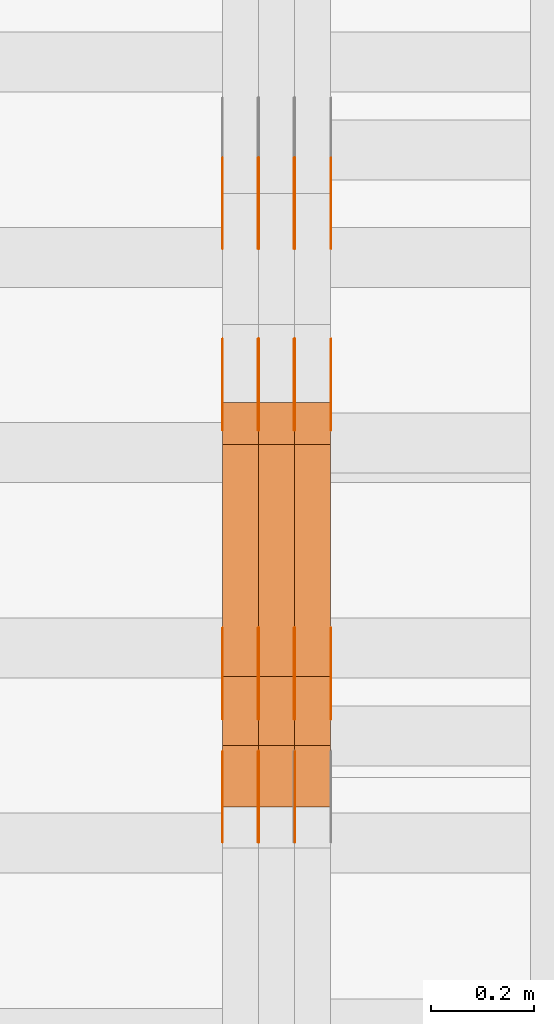
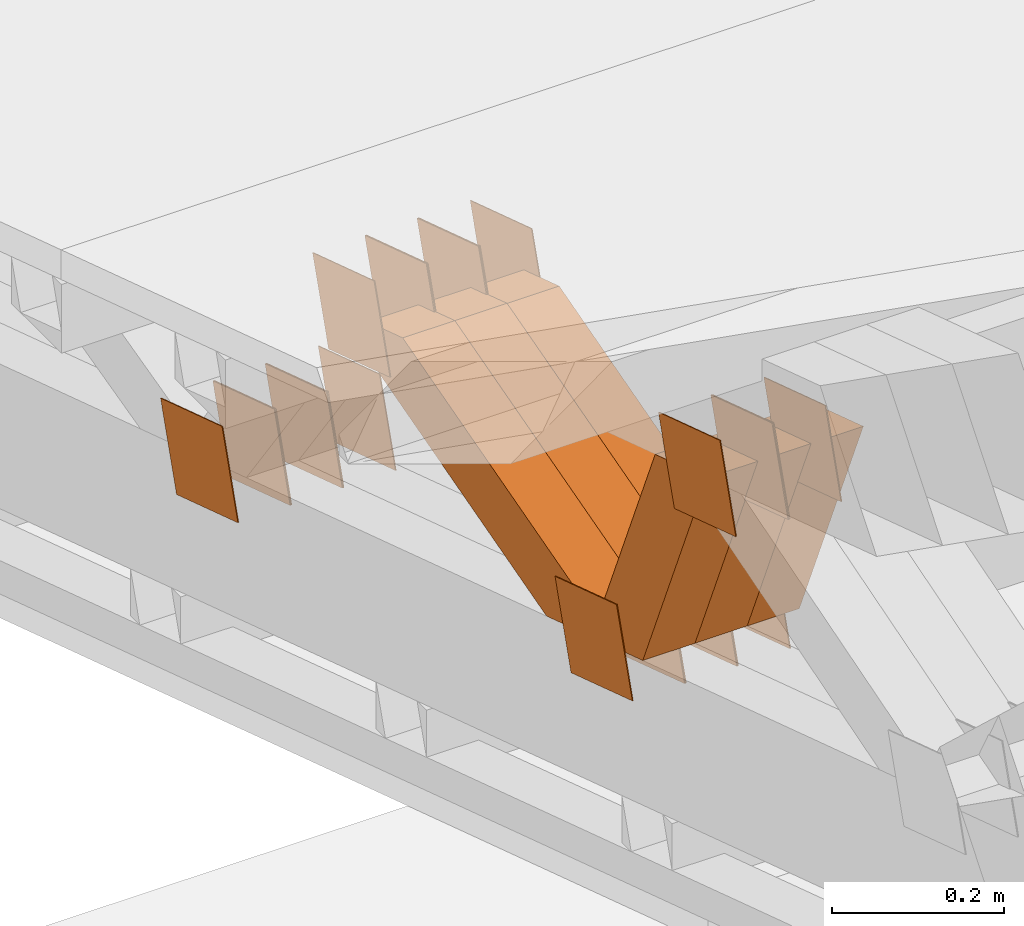
# One storey, part 181 of 385: 28 proxies.
"""IFC2X3 building model written with IfcOpenShell, lengths in millimetres."""

import ifcopenshell
import ifcopenshell.guid

model = None  # the IFC model being written
_history = None  # IfcOwnerHistory: only IFC2X3 demands one
_inside = {}  # id of a spatial element -> (the spatial element, [elements in it])
_under = {}  # id of a project, library or spatial element -> (it, [spatial elements below it])
_declared = {}  # id of a project -> (the project, [libraries it declares])
_typed = {}  # id of a type object -> (the type object, [elements of that type])
_made_of = {}  # id of a material, layer set ... -> (it, [elements and type objects made of it])


def new_model(schema):
    """Start an empty IFC model of exactly this schema.

    Asked for "IFC4X3", IfcOpenShell would pick the latest addendum, in which some entities
    have other attributes; the version numbers below select the first issue.
    IFC2X3 requires an IfcOwnerHistory on every rooted entity: one is made here for all.
    """
    global model, _history
    if schema == "IFC4X3":
        model = ifcopenshell.file(schema_version=(4, 3, 0, 0))
    else:
        model = ifcopenshell.file(schema=schema)
    _inside.clear()
    _under.clear()
    _declared.clear()
    _typed.clear()
    _made_of.clear()
    _history = None
    if model.schema == "IFC2X3":
        org = make("IfcOrganization", Name="unknown")
        user = make(
            "IfcPersonAndOrganization",
            ThePerson=make("IfcPerson", FamilyName="unknown"),
            TheOrganization=org,
        )
        app = make(
            "IfcApplication",
            ApplicationDeveloper=org,
            Version="unknown",
            ApplicationFullName="unknown",
            ApplicationIdentifier="unknown",
        )
        _history = make(
            "IfcOwnerHistory",
            OwningUser=user,
            OwningApplication=app,
            ChangeAction="ADDED",
            CreationDate=0,
        )
    return model


def make(cls, **values):
    """One entity of the class cls with the attributes given. An attribute that is None is left unset."""
    return model.create_entity(
        cls, **{name: value for name, value in values.items() if value is not None}
    )


def entity(cls, *values):
    """Any entity or typed value of the class cls, its attributes in the order of the schema. None: left unset."""
    e = model.create_entity(cls)
    for i, value in enumerate(values):
        if value is not None:
            e[i] = value
    return e


def rooted(cls, **values):
    """An entity with a GlobalId (a new one), such as an element, a storey or a relation."""
    return make(cls, GlobalId=ifcopenshell.guid.new(), OwnerHistory=_history, **values)


def si_unit(unit_type, name, prefix=None):
    """IfcSIUnit, for example si_unit("LENGTHUNIT", "METRE", prefix="MILLI")."""
    return make("IfcSIUnit", UnitType=unit_type, Prefix=prefix, Name=name)


def converted_unit(unit_type, name, factor, base, dimensions=None, offset=None):
    """IfcConversionBasedUnit, such as the inch: factor (a typed value) times the base unit."""
    return make(
        "IfcConversionBasedUnit"
        if offset is None
        else "IfcConversionBasedUnitWithOffset",
        ConversionOffset=offset,
        Dimensions=None
        if dimensions is None
        else entity("IfcDimensionalExponents", *dimensions),
        UnitType=unit_type,
        Name=name,
        ConversionFactor=make(
            "IfcMeasureWithUnit", ValueComponent=factor, UnitComponent=base
        ),
    )


def derived_unit(unit_type, elements):
    """IfcDerivedUnit: a product of units, each with its exponent."""
    return make(
        "IfcDerivedUnit",
        Elements=[
            make("IfcDerivedUnitElement", Unit=unit, Exponent=power)
            for unit, power in elements
        ],
        UnitType=unit_type,
    )


def assignment(units):
    """IfcUnitAssignment: the units of a project."""
    return None if units is None else make("IfcUnitAssignment", Units=units)


def point(xyz):
    """IfcCartesianPoint."""
    return None if xyz is None else make("IfcCartesianPoint", Coordinates=xyz)


def direction(xyz):
    """IfcDirection."""
    return None if xyz is None else make("IfcDirection", DirectionRatios=xyz)


def frame(location, z_axis=None, x_axis=None):
    """IfcAxis2Placement3D, a coordinate frame: its origin and axes. An axis left out is left unset."""
    return make(
        "IfcAxis2Placement3D",
        Location=point(location),
        Axis=direction(z_axis),
        RefDirection=direction(x_axis),
    )


def origin():
    """The frame at (0, 0, 0) with its axes left unset."""
    return frame((0.0, 0.0, 0.0))


def place(relative_to, where):
    """IfcLocalPlacement: puts the frame where relative to a parent placement (None: the world)."""
    return make(
        "IfcLocalPlacement", PlacementRelTo=relative_to, RelativePlacement=where
    )


def context(
    kind, dimensions, precision=None, world=None, true_north=None, identifier=None
):
    """IfcGeometricRepresentationContext, for example the 3D "Model" context."""
    return make(
        "IfcGeometricRepresentationContext",
        ContextIdentifier=identifier,
        ContextType=kind,
        CoordinateSpaceDimension=dimensions,
        Precision=precision,
        WorldCoordinateSystem=world,
        TrueNorth=true_north,
    )


def subcontext(parent, identifier, kind, view, scale=None):
    """IfcGeometricRepresentationSubContext, for example "Body" below "Model"."""
    return make(
        "IfcGeometricRepresentationSubContext",
        ContextIdentifier=identifier,
        ContextType=kind,
        ParentContext=parent,
        TargetScale=scale,
        TargetView=view,
    )


def project(units=None, contexts=None):
    """IfcProject with its units and contexts."""
    return rooted(
        "IfcProject",
        Name="project",
        RepresentationContexts=contexts,
        UnitsInContext=assignment(units),
    )


def spatial(cls, under=None, at=None, **own):
    """A site, building, storey or space (cls), placed at a placement, below another one or the project."""
    s = rooted(cls, ObjectPlacement=at, **own)
    if under is not None:
        _under.setdefault(under.id(), (under, []))[1].append(s)
    return s


def polyline(points):
    """IfcPolyline through the points."""
    return make("IfcPolyline", Points=[point(p) for p in points])


def outline(outer, holes=None, kind="AREA"):
    """IfcArbitraryClosedProfileDef: a profile drawn as a closed curve; with holes, ...WithVoids."""
    if holes is None:
        return make("IfcArbitraryClosedProfileDef", ProfileType=kind, OuterCurve=outer)
    return make(
        "IfcArbitraryProfileDefWithVoids",
        ProfileType=kind,
        OuterCurve=outer,
        InnerCurves=holes,
    )


def extrude(swept, where, along, depth):
    """IfcExtrudedAreaSolid: the profile swept, set in the frame where, extruded along a direction by depth."""
    return make(
        "IfcExtrudedAreaSolid",
        SweptArea=swept,
        Position=where,
        ExtrudedDirection=direction(along),
        Depth=depth,
    )


def shape(context_of_items, identifier, shape_type, items):
    """IfcShapeRepresentation: the items that make up one representation, for example the "Body"."""
    return make(
        "IfcShapeRepresentation",
        ContextOfItems=context_of_items,
        RepresentationIdentifier=identifier,
        RepresentationType=shape_type,
        Items=items,
    )


def source(mapping_origin, context_of_items, identifier, shape_type, items):
    """IfcRepresentationMap: a shape defined once, which mapped items show again and again."""
    return make(
        "IfcRepresentationMap",
        MappingOrigin=mapping_origin,
        MappedRepresentation=shape(context_of_items, identifier, shape_type, items),
    )


def transform(
    local_origin,
    x_axis=None,
    y_axis=None,
    z_axis=None,
    scale=None,
    scale2=None,
    scale3=None,
    uniform=True,
):
    """IfcCartesianTransformationOperator3D, or its non-uniform kind. x_axis, y_axis, z_axis: its Axis1, 2, 3."""
    if uniform:
        return make(
            "IfcCartesianTransformationOperator3D",
            Axis1=direction(x_axis),
            Axis2=direction(y_axis),
            LocalOrigin=point(local_origin),
            Scale=scale,
            Axis3=direction(z_axis),
        )
    return make(
        "IfcCartesianTransformationOperator3DnonUniform",
        Axis1=direction(x_axis),
        Axis2=direction(y_axis),
        LocalOrigin=point(local_origin),
        Scale=scale,
        Axis3=direction(z_axis),
        Scale2=scale2,
        Scale3=scale3,
    )


def mapped(mapping_source, mapping_target):
    """IfcMappedItem: shows the shape of a source again, moved by a transform."""
    return make(
        "IfcMappedItem", MappingSource=mapping_source, MappingTarget=mapping_target
    )


def material(Name=None, Category=None):
    """IfcMaterial."""
    return make("IfcMaterial", Name=Name, Category=Category)


def made_of(thing, what):
    """Note that an element or type object is made of a material, layer set ...; save() writes the relation."""
    if what is not None:
        _made_of.setdefault(what.id(), (what, []))[1].append(thing)
    return thing


def type_object(cls, material=None, **own):
    """A type object (cls), such as IfcWallType, which elements share."""
    return made_of(rooted(cls, **own), material)


def type_shapes(of_type, sources):
    """Give a type object the sources (RepresentationMaps) that its elements show as mapped items."""
    of_type.RepresentationMaps = sources


def element(
    cls,
    number,
    at=None,
    inside=None,
    cuts=None,
    type_object=None,
    material=None,
    context=None,
    identifier="Body",
    shape_type=None,
    held_by="IfcProductDefinitionShape",
    body=None,
    shapes=None,
    **own,
):
    """One element of the class cls, such as IfcWall. Its Tag is "e" and its number.

    at: its placement. inside: the storey or other place that contains it. cuts: it is an
    opening in that element (IfcRelVoidsElement). A single representation is given by context,
    identifier, shape_type and body (its items); several are given by shapes. held_by: the class
    of the entity that holds the representations. save() writes the other relations.
    """
    e = rooted(cls, Tag="e%d" % number, ObjectPlacement=at, **own)
    if body is not None:
        shapes = [shape(context, identifier, shape_type, body)]
    if shapes is not None:
        e.Representation = make(held_by, Representations=shapes)
    if inside is not None:
        _inside.setdefault(inside.id(), (inside, []))[1].append(e)
    if cuts is not None:
        rooted(
            "IfcRelVoidsElement", RelatingBuildingElement=cuts, RelatedOpeningElement=e
        )
    if type_object is not None:
        _typed.setdefault(type_object.id(), (type_object, []))[1].append(e)
    return made_of(e, material)


def aggregate(whole, parts):
    """IfcRelAggregates: a whole, such as a stair, and the parts it consists of."""
    return rooted("IfcRelAggregates", RelatingObject=whole, RelatedObjects=parts)


def save(model, path):
    """Write the relations noted so far, then the file.

    IfcRelAggregates (storeys below a building ...), IfcRelContainedInSpatialStructure (elements
    in a storey), IfcRelDefinesByType, IfcRelAssociatesMaterial and IfcRelDeclares: one each for
    every whole, place, type object, material and project.
    """
    for whole, parts in _under.values():
        aggregate(whole, parts)
    for where, things in _inside.values():
        rooted(
            "IfcRelContainedInSpatialStructure",
            RelatedElements=things,
            RelatingStructure=where,
        )
    for kind, things in _typed.values():
        rooted("IfcRelDefinesByType", RelatedObjects=things, RelatingType=kind)
    for what, things in _made_of.values():
        rooted("IfcRelAssociatesMaterial", RelatedObjects=things, RelatingMaterial=what)
    for by, libraries in _declared.values():
        rooted("IfcRelDeclares", RelatingContext=by, RelatedDefinitions=libraries)
    model.write(path)


model = new_model("IFC2X3")

# Units and contexts
model_context = context("Model", 3, precision=0.01, world=origin(), true_north=direction((6.12303176911189e-17, 1.0)))
body_context = subcontext(model_context, "Body", "Model", "MODEL_VIEW")
ifc_project = project(units=[si_unit("LENGTHUNIT", "METRE", prefix="MILLI"), si_unit("AREAUNIT", "SQUARE_METRE"), si_unit("VOLUMEUNIT", "CUBIC_METRE"), converted_unit("PLANEANGLEUNIT", "DEGREE", entity("IfcRatioMeasure", 0.0174532925199433), si_unit("PLANEANGLEUNIT", "RADIAN"), dimensions=[0, 0, 0, 0, 0, 0, 0]), si_unit("MASSUNIT", "GRAM", prefix="KILO"), derived_unit("MASSDENSITYUNIT", [(si_unit("MASSUNIT", "GRAM", prefix="KILO"), 1), (si_unit("LENGTHUNIT", "METRE"), -3)]), si_unit("TIMEUNIT", "SECOND"), si_unit("FREQUENCYUNIT", "HERTZ"), si_unit("THERMODYNAMICTEMPERATUREUNIT", "DEGREE_CELSIUS"), derived_unit("THERMALTRANSMITTANCEUNIT", [(si_unit("MASSUNIT", "GRAM", prefix="KILO"), 1), (si_unit("THERMODYNAMICTEMPERATUREUNIT", "KELVIN"), -1), (si_unit("TIMEUNIT", "SECOND"), -3)]), derived_unit("VOLUMETRICFLOWRATEUNIT", [(si_unit("LENGTHUNIT", "METRE"), 3), (si_unit("TIMEUNIT", "SECOND"), -1)]), si_unit("ELECTRICCURRENTUNIT", "AMPERE"), si_unit("ELECTRICVOLTAGEUNIT", "VOLT"), si_unit("POWERUNIT", "WATT"), si_unit("FORCEUNIT", "NEWTON", prefix="KILO"), si_unit("ILLUMINANCEUNIT", "LUX"), si_unit("LUMINOUSFLUXUNIT", "LUMEN"), si_unit("LUMINOUSINTENSITYUNIT", "CANDELA"), derived_unit("USERDEFINED", [(si_unit("MASSUNIT", "GRAM", prefix="KILO"), -1), (si_unit("LENGTHUNIT", "METRE"), -2), (si_unit("TIMEUNIT", "SECOND"), 3), (si_unit("LUMINOUSFLUXUNIT", "LUMEN"), 1)]), derived_unit("LINEARVELOCITYUNIT", [(si_unit("LENGTHUNIT", "METRE"), 1), (si_unit("TIMEUNIT", "SECOND"), -1)]), si_unit("PRESSUREUNIT", "PASCAL"), derived_unit("USERDEFINED", [(si_unit("LENGTHUNIT", "METRE"), -2), (si_unit("MASSUNIT", "GRAM", prefix="KILO"), 1), (si_unit("TIMEUNIT", "SECOND"), -2)])], contexts=[model_context])

# Site, building, storey
site_placement = place(None, origin())
site = spatial("IfcSite", under=ifc_project, at=site_placement, CompositionType="ELEMENT")
building_placement = place(site_placement, origin())
building = spatial("IfcBuilding", under=site, at=building_placement, CompositionType="ELEMENT")
storey_placement = place(building_placement, origin())
storey = spatial("IfcBuildingStorey", under=building, at=storey_placement, Name="Default", CompositionType="ELEMENT", Elevation=0.0)

# Proxies
ifc_material_1 = material(Name="IfcSurfaceStyle #24212")
building_element_proxy_type_1 = type_object("IfcBuildingElementProxyType", PredefinedType="NOTDEFINED", material=ifc_material_1)
shared_shape_1 = source(origin(), body_context, "Body", "SweptSolid", [
    extrude(outline(polyline([(-74.9998888504569, -59.9999264677525), (74.999884859074, -59.9999264677525), (74.9998699895559, 59.9999264677525), (-74.999865998173, 59.9999264677525), (-74.9998888504569, -59.9999264677525)])), frame((74.9999170714918, 60.0000016373507, 0.0), z_axis=(0.0, 0.0, 1.0), x_axis=(-1.0, 0.0, 0.0)), (0.0, 0.0, 1.0), 1.3),
])
type_shapes(building_element_proxy_type_1, [shared_shape_1])
proxy_1_placement = place(building_placement, frame((316.299999999986, 23182.5962361838, 1409.76695322432), z_axis=(-1.0, 0.0, 0.0), x_axis=(0.0, -0.951056516295154, 0.309016994374948)))
element("IfcBuildingElementProxy", 1, at=proxy_1_placement, inside=storey, type_object=building_element_proxy_type_1, material=ifc_material_1, context=body_context, shape_type="MappedRepresentation", body=[
    mapped(shared_shape_1, transform((0.0, 0.0, 0.0), scale=1.0)),
])
ifc_material_2 = material(Name="IfcSurfaceStyle #24155")
building_element_proxy_type_2 = type_object("IfcBuildingElementProxyType", PredefinedType="NOTDEFINED", material=ifc_material_2)
shared_shape_2 = source(origin(), body_context, "Body", "SweptSolid", [
    extrude(outline(polyline([(-74.9998888504569, -59.9999264677525), (74.999884859074, -59.9999264677525), (74.9998699895559, 59.9999264677525), (-74.999865998173, 59.9999264677525), (-74.9998888504569, -59.9999264677525)])), frame((74.9999170714918, 60.0000016373507, 0.0), z_axis=(0.0, 0.0, 1.0), x_axis=(-1.0, 0.0, 0.0)), (0.0, 0.0, 1.0), 1.29999999999999),
])
type_shapes(building_element_proxy_type_2, [shared_shape_2])
proxy_2_placement = place(building_placement, frame((245.0, 23182.5962361838, 1409.76695322432), z_axis=(-1.0, 0.0, 0.0), x_axis=(0.0, -0.951056516295154, 0.309016994374948)))
element("IfcBuildingElementProxy", 2, at=proxy_2_placement, inside=storey, type_object=building_element_proxy_type_2, material=ifc_material_2, context=body_context, shape_type="MappedRepresentation", body=[
    mapped(shared_shape_2, transform((0.0, 0.0, 0.0), scale=1.0)),
])
ifc_material_3 = material(Name="IfcSurfaceStyle #24098")
building_element_proxy_type_3 = type_object("IfcBuildingElementProxyType", PredefinedType="NOTDEFINED", material=ifc_material_3)
shared_shape_3 = source(origin(), body_context, "Body", "SweptSolid", [
    extrude(outline(polyline([(-74.9998888504569, -59.9999264677525), (74.999884859074, -59.9999264677525), (74.9998699895559, 59.9999264677525), (-74.999865998173, 59.9999264677525), (-74.9998888504569, -59.9999264677525)])), frame((74.9999170714918, 60.0000016373507, 0.0), z_axis=(0.0, 0.0, 1.0), x_axis=(-1.0, 0.0, 0.0)), (0.0, 0.0, 1.0), 1.29999999999999),
])
type_shapes(building_element_proxy_type_3, [shared_shape_3])
proxy_3_placement = place(building_placement, frame((246.299999999986, 23182.5962361838, 1409.76695322432), z_axis=(-1.0, 0.0, 0.0), x_axis=(0.0, -0.951056516295154, 0.309016994374948)))
element("IfcBuildingElementProxy", 3, at=proxy_3_placement, inside=storey, type_object=building_element_proxy_type_3, material=ifc_material_3, context=body_context, shape_type="MappedRepresentation", body=[
    mapped(shared_shape_3, transform((0.0, 0.0, 0.0), scale=1.0)),
])
ifc_material_4 = material(Name="IfcSurfaceStyle #24041")
building_element_proxy_type_4 = type_object("IfcBuildingElementProxyType", PredefinedType="NOTDEFINED", material=ifc_material_4)
shared_shape_4 = source(origin(), body_context, "Body", "SweptSolid", [
    extrude(outline(polyline([(-74.9998888504569, -59.9999264677525), (74.999884859074, -59.9999264677525), (74.9998699895559, 59.9999264677525), (-74.999865998173, 59.9999264677525), (-74.9998888504569, -59.9999264677525)])), frame((74.9999170714918, 60.0000016373507, 0.0), z_axis=(0.0, 0.0, 1.0), x_axis=(-1.0, 0.0, 0.0)), (0.0, 0.0, 1.0), 1.29999999999999),
])
type_shapes(building_element_proxy_type_4, [shared_shape_4])
proxy_4_placement = place(building_placement, frame((175.0, 23182.5962361838, 1409.76695322432), z_axis=(-1.0, 0.0, 0.0), x_axis=(0.0, -0.951056516295154, 0.309016994374948)))
element("IfcBuildingElementProxy", 4, at=proxy_4_placement, inside=storey, type_object=building_element_proxy_type_4, material=ifc_material_4, context=body_context, shape_type="MappedRepresentation", body=[
    mapped(shared_shape_4, transform((0.0, 0.0, 0.0), scale=1.0)),
])
ifc_material_5 = material(Name="IfcSurfaceStyle #23984")
building_element_proxy_type_5 = type_object("IfcBuildingElementProxyType", PredefinedType="NOTDEFINED", material=ifc_material_5)
shared_shape_5 = source(origin(), body_context, "Body", "SweptSolid", [
    extrude(outline(polyline([(-75.000111611545, -60.0000599592451), (75.0000887592491, -60.0000599592451), (75.000111611545, 60.0000599592451), (-75.0000887592492, 60.0000599592451), (-75.000111611545, -60.0000599592451)])), frame((75.000111611545, 60.0000599592451, 0.0), z_axis=(0.0, 0.0, 1.0), x_axis=(-1.0, 0.0, 0.0)), (0.0, 0.0, 1.0), 1.3),
])
type_shapes(building_element_proxy_type_5, [shared_shape_5])
proxy_5_placement = place(building_placement, frame((386.299999999986, 23422.738257852, 1031.33757447264), z_axis=(-1.0, 0.0, 0.0), x_axis=(0.0, -0.951056516295124, 0.309016994375039)))
element("IfcBuildingElementProxy", 5, at=proxy_5_placement, inside=storey, type_object=building_element_proxy_type_5, material=ifc_material_5, context=body_context, shape_type="MappedRepresentation", body=[
    mapped(shared_shape_5, transform((0.0, 0.0, 0.0), scale=1.0)),
])
ifc_material_6 = material(Name="IfcSurfaceStyle #23927")
building_element_proxy_type_6 = type_object("IfcBuildingElementProxyType", PredefinedType="NOTDEFINED", material=ifc_material_6)
shared_shape_6 = source(origin(), body_context, "Body", "SweptSolid", [
    extrude(outline(polyline([(-75.000111611545, -60.0000599592451), (75.0000887592491, -60.0000599592451), (75.000111611545, 60.0000599592451), (-75.0000887592492, 60.0000599592451), (-75.000111611545, -60.0000599592451)])), frame((75.000111611545, 60.0000599592451, 0.0), z_axis=(0.0, 0.0, 1.0), x_axis=(-1.0, 0.0, 0.0)), (0.0, 0.0, 1.0), 1.3),
])
type_shapes(building_element_proxy_type_6, [shared_shape_6])
proxy_6_placement = place(building_placement, frame((315.0, 23422.738257852, 1031.33757447264), z_axis=(-1.0, 0.0, 0.0), x_axis=(0.0, -0.951056516295124, 0.309016994375039)))
element("IfcBuildingElementProxy", 6, at=proxy_6_placement, inside=storey, type_object=building_element_proxy_type_6, material=ifc_material_6, context=body_context, shape_type="MappedRepresentation", body=[
    mapped(shared_shape_6, transform((0.0, 0.0, 0.0), scale=1.0)),
])
ifc_material_7 = material(Name="IfcSurfaceStyle #23870")
building_element_proxy_type_7 = type_object("IfcBuildingElementProxyType", PredefinedType="NOTDEFINED", material=ifc_material_7)
shared_shape_7 = source(origin(), body_context, "Body", "SweptSolid", [
    extrude(outline(polyline([(-75.000111611545, -60.0000599592451), (75.0000887592491, -60.0000599592451), (75.000111611545, 60.0000599592451), (-75.0000887592492, 60.0000599592451), (-75.000111611545, -60.0000599592451)])), frame((75.000111611545, 60.0000599592451, 0.0), z_axis=(0.0, 0.0, 1.0), x_axis=(-1.0, 0.0, 0.0)), (0.0, 0.0, 1.0), 1.3),
])
type_shapes(building_element_proxy_type_7, [shared_shape_7])
proxy_7_placement = place(building_placement, frame((316.299999999986, 23422.738257852, 1031.33757447264), z_axis=(-1.0, 0.0, 0.0), x_axis=(0.0, -0.951056516295124, 0.309016994375039)))
element("IfcBuildingElementProxy", 7, at=proxy_7_placement, inside=storey, type_object=building_element_proxy_type_7, material=ifc_material_7, context=body_context, shape_type="MappedRepresentation", body=[
    mapped(shared_shape_7, transform((0.0, 0.0, 0.0), scale=1.0)),
])
ifc_material_8 = material(Name="IfcSurfaceStyle #23813")
building_element_proxy_type_8 = type_object("IfcBuildingElementProxyType", PredefinedType="NOTDEFINED", material=ifc_material_8)
shared_shape_8 = source(origin(), body_context, "Body", "SweptSolid", [
    extrude(outline(polyline([(-75.000111611545, -60.0000599592451), (75.0000887592491, -60.0000599592451), (75.000111611545, 60.0000599592451), (-75.0000887592492, 60.0000599592451), (-75.000111611545, -60.0000599592451)])), frame((75.000111611545, 60.0000599592451, 0.0), z_axis=(0.0, 0.0, 1.0), x_axis=(-1.0, 0.0, 0.0)), (0.0, 0.0, 1.0), 1.29999999999999),
])
type_shapes(building_element_proxy_type_8, [shared_shape_8])
proxy_8_placement = place(building_placement, frame((245.0, 23422.738257852, 1031.33757447264), z_axis=(-1.0, 0.0, 0.0), x_axis=(0.0, -0.951056516295124, 0.309016994375039)))
element("IfcBuildingElementProxy", 8, at=proxy_8_placement, inside=storey, type_object=building_element_proxy_type_8, material=ifc_material_8, context=body_context, shape_type="MappedRepresentation", body=[
    mapped(shared_shape_8, transform((0.0, 0.0, 0.0), scale=1.0)),
])
ifc_material_9 = material(Name="IfcSurfaceStyle #23756")
building_element_proxy_type_9 = type_object("IfcBuildingElementProxyType", PredefinedType="NOTDEFINED", material=ifc_material_9)
shared_shape_9 = source(origin(), body_context, "Body", "SweptSolid", [
    extrude(outline(polyline([(-75.000111611545, -60.0000599592451), (75.0000887592491, -60.0000599592451), (75.000111611545, 60.0000599592451), (-75.0000887592492, 60.0000599592451), (-75.000111611545, -60.0000599592451)])), frame((75.000111611545, 60.0000599592451, 0.0), z_axis=(0.0, 0.0, 1.0), x_axis=(-1.0, 0.0, 0.0)), (0.0, 0.0, 1.0), 1.29999999999999),
])
type_shapes(building_element_proxy_type_9, [shared_shape_9])
proxy_9_placement = place(building_placement, frame((246.299999999986, 23422.738257852, 1031.33757447264), z_axis=(-1.0, 0.0, 0.0), x_axis=(0.0, -0.951056516295124, 0.309016994375039)))
element("IfcBuildingElementProxy", 9, at=proxy_9_placement, inside=storey, type_object=building_element_proxy_type_9, material=ifc_material_9, context=body_context, shape_type="MappedRepresentation", body=[
    mapped(shared_shape_9, transform((0.0, 0.0, 0.0), scale=1.0)),
])
ifc_material_10 = material(Name="IfcSurfaceStyle #23699")
building_element_proxy_type_10 = type_object("IfcBuildingElementProxyType", PredefinedType="NOTDEFINED", material=ifc_material_10)
shared_shape_10 = source(origin(), body_context, "Body", "SweptSolid", [
    extrude(outline(polyline([(-75.000111611545, -60.0000599592451), (75.0000887592491, -60.0000599592451), (75.000111611545, 60.0000599592451), (-75.0000887592492, 60.0000599592451), (-75.000111611545, -60.0000599592451)])), frame((75.000111611545, 60.0000599592451, 0.0), z_axis=(0.0, 0.0, 1.0), x_axis=(-1.0, 0.0, 0.0)), (0.0, 0.0, 1.0), 1.29999999999999),
])
type_shapes(building_element_proxy_type_10, [shared_shape_10])
proxy_10_placement = place(building_placement, frame((175.0, 23422.738257852, 1031.33757447264), z_axis=(-1.0, 0.0, 0.0), x_axis=(0.0, -0.951056516295124, 0.309016994375039)))
element("IfcBuildingElementProxy", 10, at=proxy_10_placement, inside=storey, type_object=building_element_proxy_type_10, material=ifc_material_10, context=body_context, shape_type="MappedRepresentation", body=[
    mapped(shared_shape_10, transform((0.0, 0.0, 0.0), scale=1.0)),
])
ifc_material_11 = material(Name="IfcSurfaceStyle #23300")
building_element_proxy_type_11 = type_object("IfcBuildingElementProxyType", PredefinedType="NOTDEFINED", material=ifc_material_11)
shared_shape_11 = source(origin(), body_context, "Body", "SweptSolid", [
    extrude(outline(polyline([(-74.9999766548731, -60.0000019113547), (75.000223715922, -60.0000019113547), (74.9997444633404, 60.0000019113548), (-74.9999915243893, 60.0000019113547), (-74.9999766548731, -60.0000019113547)])), frame((75.0002237159219, 60.0000770809529, 0.0), z_axis=(0.0, 0.0, 1.0), x_axis=(-1.0, 0.0, 0.0)), (0.0, 0.0, 1.0), 1.3),
])
type_shapes(building_element_proxy_type_11, [shared_shape_11])
proxy_11_placement = place(building_placement, frame((386.299999999986, 23985.88473314, 1148.76266928562), z_axis=(-1.0, 0.0, 0.0), x_axis=(0.0, -0.951056516295154, 0.309016994374948)))
element("IfcBuildingElementProxy", 11, at=proxy_11_placement, inside=storey, type_object=building_element_proxy_type_11, material=ifc_material_11, context=body_context, shape_type="MappedRepresentation", body=[
    mapped(shared_shape_11, transform((0.0, 0.0, 0.0), scale=1.0)),
])
ifc_material_12 = material(Name="IfcSurfaceStyle #23243")
building_element_proxy_type_12 = type_object("IfcBuildingElementProxyType", PredefinedType="NOTDEFINED", material=ifc_material_12)
shared_shape_12 = source(origin(), body_context, "Body", "SweptSolid", [
    extrude(outline(polyline([(-74.9999766548731, -60.0000019113547), (75.000223715922, -60.0000019113547), (74.9997444633404, 60.0000019113548), (-74.9999915243893, 60.0000019113547), (-74.9999766548731, -60.0000019113547)])), frame((75.0002237159219, 60.0000770809529, 0.0), z_axis=(0.0, 0.0, 1.0), x_axis=(-1.0, 0.0, 0.0)), (0.0, 0.0, 1.0), 1.3),
])
type_shapes(building_element_proxy_type_12, [shared_shape_12])
proxy_12_placement = place(building_placement, frame((315.0, 23985.88473314, 1148.76266928562), z_axis=(-1.0, 0.0, 0.0), x_axis=(0.0, -0.951056516295154, 0.309016994374948)))
element("IfcBuildingElementProxy", 12, at=proxy_12_placement, inside=storey, type_object=building_element_proxy_type_12, material=ifc_material_12, context=body_context, shape_type="MappedRepresentation", body=[
    mapped(shared_shape_12, transform((0.0, 0.0, 0.0), scale=1.0)),
])
ifc_material_13 = material(Name="IfcSurfaceStyle #23186")
building_element_proxy_type_13 = type_object("IfcBuildingElementProxyType", PredefinedType="NOTDEFINED", material=ifc_material_13)
shared_shape_13 = source(origin(), body_context, "Body", "SweptSolid", [
    extrude(outline(polyline([(-74.9999766548731, -60.0000019113547), (75.000223715922, -60.0000019113547), (74.9997444633404, 60.0000019113548), (-74.9999915243893, 60.0000019113547), (-74.9999766548731, -60.0000019113547)])), frame((75.0002237159219, 60.0000770809529, 0.0), z_axis=(0.0, 0.0, 1.0), x_axis=(-1.0, 0.0, 0.0)), (0.0, 0.0, 1.0), 1.3),
])
type_shapes(building_element_proxy_type_13, [shared_shape_13])
proxy_13_placement = place(building_placement, frame((316.299999999986, 23985.88473314, 1148.76266928562), z_axis=(-1.0, 0.0, 0.0), x_axis=(0.0, -0.951056516295154, 0.309016994374948)))
element("IfcBuildingElementProxy", 13, at=proxy_13_placement, inside=storey, type_object=building_element_proxy_type_13, material=ifc_material_13, context=body_context, shape_type="MappedRepresentation", body=[
    mapped(shared_shape_13, transform((0.0, 0.0, 0.0), scale=1.0)),
])
ifc_material_14 = material(Name="IfcSurfaceStyle #23129")
building_element_proxy_type_14 = type_object("IfcBuildingElementProxyType", PredefinedType="NOTDEFINED", material=ifc_material_14)
shared_shape_14 = source(origin(), body_context, "Body", "SweptSolid", [
    extrude(outline(polyline([(-74.9999766548731, -60.0000019113547), (75.000223715922, -60.0000019113547), (74.9997444633404, 60.0000019113548), (-74.9999915243893, 60.0000019113547), (-74.9999766548731, -60.0000019113547)])), frame((75.0002237159219, 60.0000770809529, 0.0), z_axis=(0.0, 0.0, 1.0), x_axis=(-1.0, 0.0, 0.0)), (0.0, 0.0, 1.0), 1.29999999999999),
])
type_shapes(building_element_proxy_type_14, [shared_shape_14])
proxy_14_placement = place(building_placement, frame((245.0, 23985.88473314, 1148.76266928562), z_axis=(-1.0, 0.0, 0.0), x_axis=(0.0, -0.951056516295154, 0.309016994374948)))
element("IfcBuildingElementProxy", 14, at=proxy_14_placement, inside=storey, type_object=building_element_proxy_type_14, material=ifc_material_14, context=body_context, shape_type="MappedRepresentation", body=[
    mapped(shared_shape_14, transform((0.0, 0.0, 0.0), scale=1.0)),
])
ifc_material_15 = material(Name="IfcSurfaceStyle #23072")
building_element_proxy_type_15 = type_object("IfcBuildingElementProxyType", PredefinedType="NOTDEFINED", material=ifc_material_15)
shared_shape_15 = source(origin(), body_context, "Body", "SweptSolid", [
    extrude(outline(polyline([(-74.9999766548731, -60.0000019113547), (75.000223715922, -60.0000019113547), (74.9997444633404, 60.0000019113548), (-74.9999915243893, 60.0000019113547), (-74.9999766548731, -60.0000019113547)])), frame((75.0002237159219, 60.0000770809529, 0.0), z_axis=(0.0, 0.0, 1.0), x_axis=(-1.0, 0.0, 0.0)), (0.0, 0.0, 1.0), 1.29999999999999),
])
type_shapes(building_element_proxy_type_15, [shared_shape_15])
proxy_15_placement = place(building_placement, frame((246.299999999986, 23985.88473314, 1148.76266928562), z_axis=(-1.0, 0.0, 0.0), x_axis=(0.0, -0.951056516295154, 0.309016994374948)))
element("IfcBuildingElementProxy", 15, at=proxy_15_placement, inside=storey, type_object=building_element_proxy_type_15, material=ifc_material_15, context=body_context, shape_type="MappedRepresentation", body=[
    mapped(shared_shape_15, transform((0.0, 0.0, 0.0), scale=1.0)),
])
ifc_material_16 = material(Name="IfcSurfaceStyle #23015")
building_element_proxy_type_16 = type_object("IfcBuildingElementProxyType", PredefinedType="NOTDEFINED", material=ifc_material_16)
shared_shape_16 = source(origin(), body_context, "Body", "SweptSolid", [
    extrude(outline(polyline([(-74.9999766548731, -60.0000019113547), (75.000223715922, -60.0000019113547), (74.9997444633404, 60.0000019113548), (-74.9999915243893, 60.0000019113547), (-74.9999766548731, -60.0000019113547)])), frame((75.0002237159219, 60.0000770809529, 0.0), z_axis=(0.0, 0.0, 1.0), x_axis=(-1.0, 0.0, 0.0)), (0.0, 0.0, 1.0), 1.29999999999999),
])
type_shapes(building_element_proxy_type_16, [shared_shape_16])
proxy_16_placement = place(building_placement, frame((175.0, 23985.88473314, 1148.76266928562), z_axis=(-1.0, 0.0, 0.0), x_axis=(0.0, -0.951056516295154, 0.309016994374948)))
element("IfcBuildingElementProxy", 16, at=proxy_16_placement, inside=storey, type_object=building_element_proxy_type_16, material=ifc_material_16, context=body_context, shape_type="MappedRepresentation", body=[
    mapped(shared_shape_16, transform((0.0, 0.0, 0.0), scale=1.0)),
])
ifc_material_17 = material(Name="IfcSurfaceStyle #22958")
building_element_proxy_type_17 = type_object("IfcBuildingElementProxyType", PredefinedType="NOTDEFINED", material=ifc_material_17)
shared_shape_17 = source(origin(), body_context, "Body", "SweptSolid", [
    extrude(outline(polyline([(-74.9998841352385, -59.9999554917014), (74.9998707133932, -59.9999554917014), (74.999874704788, 59.9999554917014), (-74.9998612829427, 59.9999554917014), (-74.9998841352385, -59.9999554917014)])), frame((75.0000802775471, 60.0000306612849, 0.0), z_axis=(0.0, 0.0, 1.0), x_axis=(-1.0, 0.0, 0.0)), (0.0, 0.0, 1.0), 1.3),
])
type_shapes(building_element_proxy_type_17, [shared_shape_17])
proxy_17_placement = place(building_placement, frame((386.299999999986, 24338.8869142613, 728.405515087805), z_axis=(-1.0, 0.0, 0.0), x_axis=(0.0, -0.951056516295124, 0.309016994375039)))
element("IfcBuildingElementProxy", 17, at=proxy_17_placement, inside=storey, type_object=building_element_proxy_type_17, material=ifc_material_17, context=body_context, shape_type="MappedRepresentation", body=[
    mapped(shared_shape_17, transform((0.0, 0.0, 0.0), scale=1.0)),
])
ifc_material_18 = material(Name="IfcSurfaceStyle #22901")
building_element_proxy_type_18 = type_object("IfcBuildingElementProxyType", PredefinedType="NOTDEFINED", material=ifc_material_18)
shared_shape_18 = source(origin(), body_context, "Body", "SweptSolid", [
    extrude(outline(polyline([(-74.9998841352385, -59.9999554917014), (74.9998707133932, -59.9999554917014), (74.999874704788, 59.9999554917014), (-74.9998612829427, 59.9999554917014), (-74.9998841352385, -59.9999554917014)])), frame((75.0000802775471, 60.0000306612849, 0.0), z_axis=(0.0, 0.0, 1.0), x_axis=(-1.0, 0.0, 0.0)), (0.0, 0.0, 1.0), 1.3),
])
type_shapes(building_element_proxy_type_18, [shared_shape_18])
proxy_18_placement = place(building_placement, frame((315.0, 24338.8869142613, 728.405515087805), z_axis=(-1.0, 0.0, 0.0), x_axis=(0.0, -0.951056516295124, 0.309016994375039)))
element("IfcBuildingElementProxy", 18, at=proxy_18_placement, inside=storey, type_object=building_element_proxy_type_18, material=ifc_material_18, context=body_context, shape_type="MappedRepresentation", body=[
    mapped(shared_shape_18, transform((0.0, 0.0, 0.0), scale=1.0)),
])
ifc_material_19 = material(Name="IfcSurfaceStyle #22844")
building_element_proxy_type_19 = type_object("IfcBuildingElementProxyType", PredefinedType="NOTDEFINED", material=ifc_material_19)
shared_shape_19 = source(origin(), body_context, "Body", "SweptSolid", [
    extrude(outline(polyline([(-74.9998841352385, -59.9999554917014), (74.9998707133932, -59.9999554917014), (74.999874704788, 59.9999554917014), (-74.9998612829427, 59.9999554917014), (-74.9998841352385, -59.9999554917014)])), frame((75.0000802775471, 60.0000306612849, 0.0), z_axis=(0.0, 0.0, 1.0), x_axis=(-1.0, 0.0, 0.0)), (0.0, 0.0, 1.0), 1.3),
])
type_shapes(building_element_proxy_type_19, [shared_shape_19])
proxy_19_placement = place(building_placement, frame((316.299999999986, 24338.8869142613, 728.405515087805), z_axis=(-1.0, 0.0, 0.0), x_axis=(0.0, -0.951056516295124, 0.309016994375039)))
element("IfcBuildingElementProxy", 19, at=proxy_19_placement, inside=storey, type_object=building_element_proxy_type_19, material=ifc_material_19, context=body_context, shape_type="MappedRepresentation", body=[
    mapped(shared_shape_19, transform((0.0, 0.0, 0.0), scale=1.0)),
])
ifc_material_20 = material(Name="IfcSurfaceStyle #22787")
building_element_proxy_type_20 = type_object("IfcBuildingElementProxyType", PredefinedType="NOTDEFINED", material=ifc_material_20)
shared_shape_20 = source(origin(), body_context, "Body", "SweptSolid", [
    extrude(outline(polyline([(-74.9998841352385, -59.9999554917014), (74.9998707133932, -59.9999554917014), (74.999874704788, 59.9999554917014), (-74.9998612829427, 59.9999554917014), (-74.9998841352385, -59.9999554917014)])), frame((75.0000802775471, 60.0000306612849, 0.0), z_axis=(0.0, 0.0, 1.0), x_axis=(-1.0, 0.0, 0.0)), (0.0, 0.0, 1.0), 1.29999999999999),
])
type_shapes(building_element_proxy_type_20, [shared_shape_20])
proxy_20_placement = place(building_placement, frame((245.0, 24338.8869142613, 728.405515087805), z_axis=(-1.0, 0.0, 0.0), x_axis=(0.0, -0.951056516295124, 0.309016994375039)))
element("IfcBuildingElementProxy", 20, at=proxy_20_placement, inside=storey, type_object=building_element_proxy_type_20, material=ifc_material_20, context=body_context, shape_type="MappedRepresentation", body=[
    mapped(shared_shape_20, transform((0.0, 0.0, 0.0), scale=1.0)),
])
ifc_material_21 = material(Name="IfcSurfaceStyle #22730")
building_element_proxy_type_21 = type_object("IfcBuildingElementProxyType", PredefinedType="NOTDEFINED", material=ifc_material_21)
shared_shape_21 = source(origin(), body_context, "Body", "SweptSolid", [
    extrude(outline(polyline([(-74.9998841352385, -59.9999554917014), (74.9998707133932, -59.9999554917014), (74.999874704788, 59.9999554917014), (-74.9998612829427, 59.9999554917014), (-74.9998841352385, -59.9999554917014)])), frame((75.0000802775471, 60.0000306612849, 0.0), z_axis=(0.0, 0.0, 1.0), x_axis=(-1.0, 0.0, 0.0)), (0.0, 0.0, 1.0), 1.29999999999999),
])
type_shapes(building_element_proxy_type_21, [shared_shape_21])
proxy_21_placement = place(building_placement, frame((246.299999999986, 24338.8869142613, 728.405515087805), z_axis=(-1.0, 0.0, 0.0), x_axis=(0.0, -0.951056516295124, 0.309016994375039)))
element("IfcBuildingElementProxy", 21, at=proxy_21_placement, inside=storey, type_object=building_element_proxy_type_21, material=ifc_material_21, context=body_context, shape_type="MappedRepresentation", body=[
    mapped(shared_shape_21, transform((0.0, 0.0, 0.0), scale=1.0)),
])
ifc_material_22 = material(Name="IfcSurfaceStyle #22673")
building_element_proxy_type_22 = type_object("IfcBuildingElementProxyType", PredefinedType="NOTDEFINED", material=ifc_material_22)
shared_shape_22 = source(origin(), body_context, "Body", "SweptSolid", [
    extrude(outline(polyline([(-74.9998841352385, -59.9999554917014), (74.9998707133932, -59.9999554917014), (74.999874704788, 59.9999554917014), (-74.9998612829427, 59.9999554917014), (-74.9998841352385, -59.9999554917014)])), frame((75.0000802775471, 60.0000306612849, 0.0), z_axis=(0.0, 0.0, 1.0), x_axis=(-1.0, 0.0, 0.0)), (0.0, 0.0, 1.0), 1.29999999999999),
])
type_shapes(building_element_proxy_type_22, [shared_shape_22])
proxy_22_placement = place(building_placement, frame((175.0, 24338.8869142613, 728.405515087805), z_axis=(-1.0, 0.0, 0.0), x_axis=(0.0, -0.951056516295124, 0.309016994375039)))
element("IfcBuildingElementProxy", 22, at=proxy_22_placement, inside=storey, type_object=building_element_proxy_type_22, material=ifc_material_22, context=body_context, shape_type="MappedRepresentation", body=[
    mapped(shared_shape_22, transform((0.0, 0.0, 0.0), scale=1.0)),
])
ifc_material_23 = material(Name="IfcSurfaceStyle #11474")
building_element_proxy_type_23 = type_object("IfcBuildingElementProxyType", Name="T1-W48 11472", PredefinedType="NOTDEFINED", material=ifc_material_23)
shared_shape_23 = source(origin(), body_context, "Body", "SweptSolid", [
    extrude(outline(polyline([(-179.014659681673, -47.5001725722734), (164.970934255612, -47.5001725722734), (158.689466064455, -0.000154807462590734), (117.249257288395, 47.5002499760047), (-261.894997926789, 47.5002499760047), (-179.014659681673, -47.5001725722734)])), frame((164.970934255612, 47.5002499760047, 0.0), z_axis=(0.0, 0.0, 1.0), x_axis=(-1.0, 0.0, 0.0)), (0.0, 0.0, 1.0), 70.0),
])
type_shapes(building_element_proxy_type_23, [shared_shape_23])
proxy_23_placement = place(building_placement, frame((385.0, 23276.999081075, 1103.96808602322), z_axis=(-1.0, 0.0, 0.0), x_axis=(0.0, -0.392372359952232, 0.919806463961586)))
element("IfcBuildingElementProxy", 23, at=proxy_23_placement, inside=storey, type_object=building_element_proxy_type_23, material=ifc_material_23, Name="T1-W48", context=body_context, shape_type="MappedRepresentation", body=[
    mapped(shared_shape_23, transform((0.0, 0.0, 0.0), scale=1.0)),
])
ifc_material_24 = material(Name="IfcSurfaceStyle #11408")
building_element_proxy_type_24 = type_object("IfcBuildingElementProxyType", Name="T1-W48 11406", PredefinedType="NOTDEFINED", material=ifc_material_24)
shared_shape_24 = source(origin(), body_context, "Body", "SweptSolid", [
    extrude(outline(polyline([(-179.014659681673, -47.5001725722734), (164.970934255612, -47.5001725722734), (158.689466064455, -0.000154807462590734), (117.249257288395, 47.5002499760047), (-261.894997926789, 47.5002499760047), (-179.014659681673, -47.5001725722734)])), frame((164.970934255612, 47.5002499760047, 0.0), z_axis=(0.0, 0.0, 1.0), x_axis=(-1.0, 0.0, 0.0)), (0.0, 0.0, 1.0), 70.0),
])
type_shapes(building_element_proxy_type_24, [shared_shape_24])
proxy_24_placement = place(building_placement, frame((315.0, 23276.999081075, 1103.96808602322), z_axis=(-1.0, 0.0, 0.0), x_axis=(0.0, -0.392372359952232, 0.919806463961586)))
element("IfcBuildingElementProxy", 24, at=proxy_24_placement, inside=storey, type_object=building_element_proxy_type_24, material=ifc_material_24, Name="T1-W48", context=body_context, shape_type="MappedRepresentation", body=[
    mapped(shared_shape_24, transform((0.0, 0.0, 0.0), scale=1.0)),
])
ifc_material_25 = material(Name="IfcSurfaceStyle #11342")
building_element_proxy_type_25 = type_object("IfcBuildingElementProxyType", Name="T1-W48 11340", PredefinedType="NOTDEFINED", material=ifc_material_25)
shared_shape_25 = source(origin(), body_context, "Body", "SweptSolid", [
    extrude(outline(polyline([(-179.014659681673, -47.5001725722734), (164.970934255612, -47.5001725722734), (158.689466064455, -0.000154807462590734), (117.249257288395, 47.5002499760047), (-261.894997926789, 47.5002499760047), (-179.014659681673, -47.5001725722734)])), frame((164.970934255612, 47.5002499760047, 0.0), z_axis=(0.0, 0.0, 1.0), x_axis=(-1.0, 0.0, 0.0)), (0.0, 0.0, 1.0), 70.0),
])
type_shapes(building_element_proxy_type_25, [shared_shape_25])
proxy_25_placement = place(building_placement, frame((245.0, 23276.999081075, 1103.96808602322), z_axis=(-1.0, 0.0, 0.0), x_axis=(0.0, -0.392372359952232, 0.919806463961586)))
element("IfcBuildingElementProxy", 25, at=proxy_25_placement, inside=storey, type_object=building_element_proxy_type_25, material=ifc_material_25, Name="T1-W48", context=body_context, shape_type="MappedRepresentation", body=[
    mapped(shared_shape_25, transform((0.0, 0.0, 0.0), scale=1.0)),
])
ifc_material_26 = material(Name="IfcSurfaceStyle #11078")
building_element_proxy_type_26 = type_object("IfcBuildingElementProxyType", Name="T1-W16 11076", PredefinedType="NOTDEFINED", material=ifc_material_26)
shared_shape_26 = source(origin(), body_context, "Body", "SweptSolid", [
    extrude(outline(polyline([(-370.757125176074, -47.4999438400901), (145.934648032773, -47.4999438400902), (217.511780472151, -4.11857860007858e-05), (234.91308660316, 47.4999644329832), (-227.602389932009, 47.4999644329832), (-370.757125176074, -47.4999438400901)])), frame((234.913162148205, 47.5000075544853, 0.0), z_axis=(0.0, 0.0, 1.0), x_axis=(-1.0, 0.0, 0.0)), (0.0, 0.0, 1.0), 70.0),
])
type_shapes(building_element_proxy_type_26, [shared_shape_26])
proxy_26_placement = place(building_placement, frame((385.0, 23927.1704945031, 1199.43003244777), z_axis=(-1.0, 0.0, 0.0), x_axis=(0.0, -0.963308155550006, -0.268397834288666)))
element("IfcBuildingElementProxy", 26, at=proxy_26_placement, inside=storey, type_object=building_element_proxy_type_26, material=ifc_material_26, Name="T1-W16", context=body_context, shape_type="MappedRepresentation", body=[
    mapped(shared_shape_26, transform((0.0, 0.0, 0.0), scale=1.0)),
])
ifc_material_27 = material(Name="IfcSurfaceStyle #11012")
building_element_proxy_type_27 = type_object("IfcBuildingElementProxyType", Name="T1-W16 11010", PredefinedType="NOTDEFINED", material=ifc_material_27)
shared_shape_27 = source(origin(), body_context, "Body", "SweptSolid", [
    extrude(outline(polyline([(-370.757125176074, -47.4999438400901), (145.934648032773, -47.4999438400902), (217.511780472151, -4.11857860007858e-05), (234.91308660316, 47.4999644329832), (-227.602389932009, 47.4999644329832), (-370.757125176074, -47.4999438400901)])), frame((234.913162148205, 47.5000075544853, 0.0), z_axis=(0.0, 0.0, 1.0), x_axis=(-1.0, 0.0, 0.0)), (0.0, 0.0, 1.0), 70.0),
])
type_shapes(building_element_proxy_type_27, [shared_shape_27])
proxy_27_placement = place(building_placement, frame((315.0, 23927.1704945031, 1199.43003244777), z_axis=(-1.0, 0.0, 0.0), x_axis=(0.0, -0.963308155550006, -0.268397834288666)))
element("IfcBuildingElementProxy", 27, at=proxy_27_placement, inside=storey, type_object=building_element_proxy_type_27, material=ifc_material_27, Name="T1-W16", context=body_context, shape_type="MappedRepresentation", body=[
    mapped(shared_shape_27, transform((0.0, 0.0, 0.0), scale=1.0)),
])
ifc_material_28 = material(Name="IfcSurfaceStyle #10946")
building_element_proxy_type_28 = type_object("IfcBuildingElementProxyType", Name="T1-W16 10944", PredefinedType="NOTDEFINED", material=ifc_material_28)
shared_shape_28 = source(origin(), body_context, "Body", "SweptSolid", [
    extrude(outline(polyline([(-370.757125176074, -47.4999438400901), (145.934648032773, -47.4999438400902), (217.511780472151, -4.11857860007858e-05), (234.91308660316, 47.4999644329832), (-227.602389932009, 47.4999644329832), (-370.757125176074, -47.4999438400901)])), frame((234.913162148205, 47.5000075544853, 0.0), z_axis=(0.0, 0.0, 1.0), x_axis=(-1.0, 0.0, 0.0)), (0.0, 0.0, 1.0), 70.0),
])
type_shapes(building_element_proxy_type_28, [shared_shape_28])
proxy_28_placement = place(building_placement, frame((245.0, 23927.1704945031, 1199.43003244777), z_axis=(-1.0, 0.0, 0.0), x_axis=(0.0, -0.963308155550006, -0.268397834288666)))
element("IfcBuildingElementProxy", 28, at=proxy_28_placement, inside=storey, type_object=building_element_proxy_type_28, material=ifc_material_28, Name="T1-W16", context=body_context, shape_type="MappedRepresentation", body=[
    mapped(shared_shape_28, transform((0.0, 0.0, 0.0), scale=1.0)),
])

save(model, "model.ifc")
